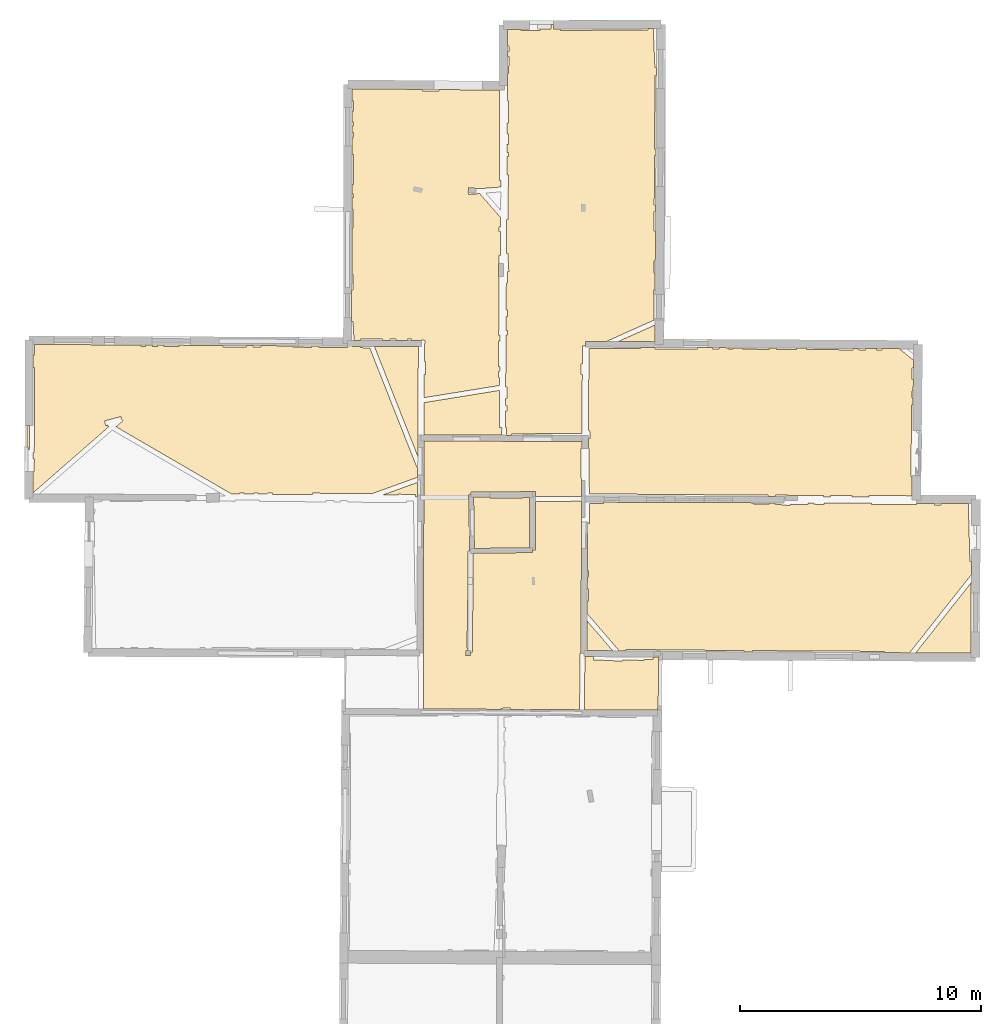
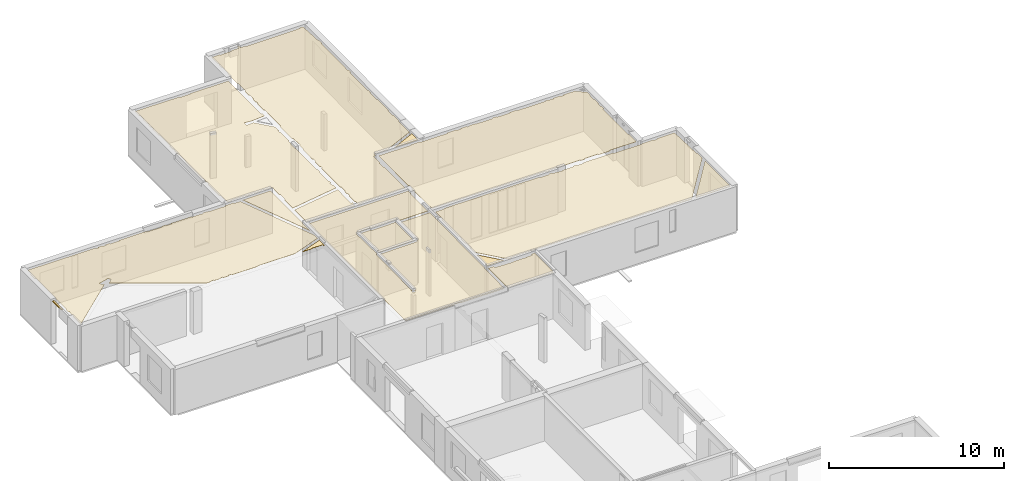
# One storey, part 11 of 14: 15 coverings.
"""IFC2X3 building model written with IfcOpenShell, lengths in metres."""

from ifc_helpers import new_model, entity, si_unit, converted_unit, derived_unit, direction, frame, origin, origin_with_axes, place, context, subcontext, project, spatial, polyline, outline, extrude, material, layer, layer_set, layer_usage, type_object, element, save


model = new_model("IFC2X3")

# Units and contexts
model_context = context("Model", 3, precision=1e-05, world=origin(), true_north=direction((0.0, 1.0)))
body_context = subcontext(model_context, "Body", "Model", "MODEL_VIEW")
ifc_project = project(units=[si_unit("LENGTHUNIT", "METRE"), si_unit("AREAUNIT", "SQUARE_METRE"), si_unit("VOLUMEUNIT", "CUBIC_METRE"), converted_unit("PLANEANGLEUNIT", "DEGREE", entity("IfcRatioMeasure", 0.0174532925199433), si_unit("PLANEANGLEUNIT", "RADIAN"), dimensions=[0, 0, 0, 0, 0, 0, 0]), si_unit("MASSUNIT", "GRAM", prefix="KILO"), derived_unit("MASSDENSITYUNIT", [(si_unit("MASSUNIT", "GRAM", prefix="KILO"), 1), (si_unit("LENGTHUNIT", "METRE"), -3)]), derived_unit("MOMENTOFINERTIAUNIT", [(si_unit("LENGTHUNIT", "METRE"), 4)]), si_unit("TIMEUNIT", "SECOND"), si_unit("FREQUENCYUNIT", "HERTZ"), si_unit("THERMODYNAMICTEMPERATUREUNIT", "DEGREE_CELSIUS"), derived_unit("THERMALTRANSMITTANCEUNIT", [(si_unit("MASSUNIT", "GRAM", prefix="KILO"), 1), (si_unit("THERMODYNAMICTEMPERATUREUNIT", "KELVIN"), -1), (si_unit("TIMEUNIT", "SECOND"), -3)]), derived_unit("VOLUMETRICFLOWRATEUNIT", [(si_unit("LENGTHUNIT", "METRE"), 3), (si_unit("TIMEUNIT", "SECOND"), -1)]), si_unit("ELECTRICCURRENTUNIT", "AMPERE"), si_unit("ELECTRICVOLTAGEUNIT", "VOLT"), si_unit("POWERUNIT", "WATT"), si_unit("FORCEUNIT", "NEWTON", prefix="KILO"), si_unit("ILLUMINANCEUNIT", "LUX"), si_unit("LUMINOUSFLUXUNIT", "LUMEN"), si_unit("LUMINOUSINTENSITYUNIT", "CANDELA"), derived_unit("USERDEFINED", [(si_unit("MASSUNIT", "GRAM", prefix="KILO"), -1), (si_unit("LENGTHUNIT", "METRE"), -2), (si_unit("TIMEUNIT", "SECOND"), 3), (si_unit("LUMINOUSFLUXUNIT", "LUMEN"), 1)]), derived_unit("LINEARVELOCITYUNIT", [(si_unit("LENGTHUNIT", "METRE"), 1), (si_unit("TIMEUNIT", "SECOND"), -1)]), si_unit("PRESSUREUNIT", "PASCAL"), derived_unit("USERDEFINED", [(si_unit("LENGTHUNIT", "METRE"), -2), (si_unit("MASSUNIT", "GRAM", prefix="KILO"), 1), (si_unit("TIMEUNIT", "SECOND"), -2)]), derived_unit("LINEARFORCEUNIT", [(si_unit("MASSUNIT", "GRAM", prefix="KILO"), 1), (si_unit("LENGTHUNIT", "METRE"), 1), (si_unit("TIMEUNIT", "SECOND"), -2), (si_unit("LENGTHUNIT", "METRE"), -1)]), derived_unit("PLANARFORCEUNIT", [(si_unit("MASSUNIT", "GRAM", prefix="KILO"), 1), (si_unit("LENGTHUNIT", "METRE"), 1), (si_unit("TIMEUNIT", "SECOND"), -2), (si_unit("LENGTHUNIT", "METRE"), -2)])], contexts=[model_context])

# Site, building, storey
placement = place(None, origin())
site = spatial("IfcSite", under=ifc_project, at=placement, CompositionType="ELEMENT")
building = spatial("IfcBuilding", under=site, at=placement, CompositionType="ELEMENT")
storey_placement = place(placement, frame((0.0, 0.0, 8.83152770996094)))
storey = spatial("IfcBuildingStorey", under=building, at=storey_placement, Name="Level 4", CompositionType="ELEMENT", Elevation=8.83152770996094)

# Coverings
ifc_material = material(Name="Covering default")
ifc_layer_1 = layer(ifc_material, 0.02)
ifc_layer_set_1 = layer_set([ifc_layer_1], Name="Covering : 20mm")
ifc_layer_usage_1 = layer_usage(ifc_layer_set_1, "AXIS3", "POSITIVE", 0.0)
covering_type_1 = type_object("IfcCoveringType", Name="Covering : 20mm", PredefinedType="CEILING")
covering_1_placement = place(placement, frame((0.0, 0.0, 11.8186979293823)))
element("IfcCovering", 1, at=covering_1_placement, inside=storey, type_object=covering_type_1, material=ifc_layer_usage_1, Name="Covering : 20mm", ObjectType="Covering : 20mm", PredefinedType="CEILING", context=body_context, shape_type="SweptSolid", body=[
    extrude(outline(polyline([(9.79597473144531, 51.0678405761719), (10.1519088745117, 51.0656089782715), (10.1472587585449, 50.9325485229492), (10.9874267578125, 50.9031867980957), (10.9875297546387, 50.8921394348145), (11.3584136962891, 50.8955879211426), (11.3580780029297, 50.9317932128906), (12.2441082000732, 50.9114570617676), (12.2447299957275, 50.9385566711426), (12.6194038391113, 50.9431991577148), (12.6180801391602, 51.0501518249512), (12.8525676727295, 51.0486793518066), (12.8424549102783, 48.9425239562988), (12.8161087036133, 48.9422988891602), (12.8169918060303, 48.840087890625), (9.77705955505371, 48.8573913574219), (9.79597473144531, 51.0678405761719)])), origin_with_axes(), (0.0, 0.0, 1.0), 0.02),
])
ifc_layer_2 = layer(ifc_material, 0.02)
ifc_layer_set_2 = layer_set([ifc_layer_2], Name="Covering : 20mm")
ifc_layer_usage_2 = layer_usage(ifc_layer_set_2, "AXIS3", "POSITIVE", 0.0)
covering_type_2 = type_object("IfcCoveringType", Name="Covering : 20mm", PredefinedType="CEILING")
covering_2_placement = place(placement, frame((0.0, 0.0, 11.8186979293823)))
element("IfcCovering", 2, at=covering_2_placement, inside=storey, type_object=covering_type_2, material=ifc_layer_usage_2, Name="Covering : 20mm", ObjectType="Covering : 20mm", PredefinedType="CEILING", context=body_context, shape_type="SweptSolid", body=[
    extrude(outline(polyline([(3.1042652130127, 60.0340843200684), (9.67360687255859, 60.002815246582), (9.67216873168945, 59.7157859802246), (9.63630294799805, 59.7155380249023), (9.65003204345703, 57.7263717651367), (7.74869728088379, 57.7208099365234), (7.7475471496582, 57.9211921691895), (7.62069702148438, 57.9204635620117), (7.62067413330078, 57.9234580993652), (5.0699462890625, 57.9058380126953), (5.07052040100098, 57.8058395385742), (4.97053146362305, 57.8043899536133), (5.00455474853516, 55.4620208740234), (4.94209480285645, 55.4621849060059), (4.93848609924316, 54.0982208251953), (4.89542388916016, 51.4237213134766), (4.93140983581543, 51.4231414794922), (4.93115615844727, 51.3274917602539), (4.85261535644531, 51.330738067627), (4.84394454956055, 51.1209182739258), (5.04377365112305, 51.1126594543457), (5.05024337768555, 51.2692070007324), (5.13100433349609, 51.2689933776855), (5.14183235168457, 55.3631134033203), (7.61702537536621, 55.392951965332), (7.61582183837891, 55.4929428100586), (7.74082183837891, 55.4926300048828), (7.74592590332031, 57.5207977294922), (9.65684127807617, 57.5263900756836), (9.65327835083008, 56.8442649841309), (9.65611839294434, 56.8442497253418), (9.65708923339844, 56.7038040161133), (9.62950325012207, 51.1940383911133), (9.59704971313477, 51.1943168640137), (9.57706260681152, 48.8585319519043), (6.69943809509277, 48.8749122619629), (6.69731903076172, 48.9332542419434), (6.3033561706543, 48.9189376831055), (6.30487442016602, 48.8771553039551), (6.18254089355469, 48.8778533935547), (6.18254089355469, 48.8778533935547), (3.08750152587891, 48.8954696655273), (3.1042652130127, 60.0340843200684)])), origin_with_axes(), (0.0, 0.0, 1.0), 0.02),
])
ifc_layer_3 = layer(ifc_material, 0.02)
ifc_layer_set_3 = layer_set([ifc_layer_3], Name="Covering : 20mm")
ifc_layer_usage_3 = layer_usage(ifc_layer_set_3, "AXIS3", "POSITIVE", 0.0)
covering_type_3 = type_object("IfcCoveringType", Name="Covering : 20mm", PredefinedType="CEILING")
covering_3_placement = place(placement, frame((0.0, 0.0, 11.8186979293823)))
element("IfcCovering", 3, at=covering_3_placement, inside=storey, type_object=covering_type_3, material=ifc_layer_usage_3, Name="Covering : 20mm", ObjectType="Covering : 20mm", PredefinedType="CEILING", context=body_context, shape_type="SweptSolid", body=[
    extrude(outline(polyline([(23.5451927185059, 51.2249374389648), (25.8534126281738, 54.147632598877), (25.8400573730469, 51.2117691040039), (23.5451927185059, 51.2249374389648)])), origin_with_axes(), (0.0, 0.0, 1.0), 0.02),
])
ifc_layer_4 = layer(ifc_material, 0.02)
ifc_layer_set_4 = layer_set([ifc_layer_4], Name="Covering : 20mm")
ifc_layer_usage_4 = layer_usage(ifc_layer_set_4, "AXIS3", "POSITIVE", 0.0)
covering_type_4 = type_object("IfcCoveringType", Name="Covering : 20mm", PredefinedType="CEILING")
covering_4_placement = place(placement, frame((0.0, 0.0, 11.8186979293823)))
element("IfcCovering", 4, at=covering_4_placement, inside=storey, type_object=covering_type_4, material=ifc_layer_usage_4, Name="Covering : 20mm", ObjectType="Covering : 20mm", PredefinedType="CEILING", context=body_context, shape_type="SweptSolid", body=[
    extrude(outline(polyline([(11.2198619842529, 51.3089218139648), (11.5025272369385, 51.3071479797363), (11.5031280517578, 51.3660087585449), (16.4032402038574, 51.3160209655762), (16.4027290344238, 51.265926361084), (16.7630500793457, 51.263858795166), (16.7633743286133, 51.3179397583008), (22.2440147399902, 51.2849273681641), (22.2436981201172, 51.2324066162109), (23.2914924621582, 51.2263946533203), (25.8548889160156, 54.4721946716309), (25.8573722839355, 55.0177688598633), (25.7986488342285, 55.0160903930664), (25.7297325134277, 57.4270515441895), (24.5905075073242, 57.4253921508789), (24.5912590026855, 57.373779296875), (24.321102142334, 57.3698425292969), (24.3202972412109, 57.4249992370605), (23.5740928649902, 57.4239120483398), (23.5738945007324, 57.380256652832), (21.7008628845215, 57.3886566162109), (21.7011108398438, 57.4442024230957), (19.7317771911621, 57.4515075683594), (19.7304611206055, 57.3928756713867), (19.2905731201172, 57.4027519226074), (19.2917060852051, 57.4531364440918), (19.0605812072754, 57.4539947509766), (19.060359954834, 57.3939971923828), (18.3142623901367, 57.3967590332031), (18.309024810791, 57.3447685241699), (17.6703071594238, 57.4091186523438), (17.6753463745117, 57.4591293334961), (17.4705448150635, 57.459888458252), (17.4701347351074, 57.4036102294922), (16.8100738525391, 57.4084243774414), (16.8104667663574, 57.4623336791992), (10.5690460205078, 57.4854698181152), (10.5689544677734, 57.4285011291504), (9.98208618164062, 57.4294471740723), (9.98776245117188, 56.6070327758789), (9.9066047668457, 56.6064720153809), (9.89682388305664, 54.652889251709), (9.95647430419922, 54.6515502929688), (9.95019149780273, 54.3716201782227), (9.89542198181152, 54.3728485107422), (9.8929615020752, 53.8816528320312), (9.94919204711914, 53.8815155029297), (9.94796752929688, 53.381420135498), (9.89045906066895, 53.3815612792969), (9.8878345489502, 52.8574829101562), (11.2198619842529, 51.3089218139648)])), origin_with_axes(), (0.0, 0.0, 1.0), 0.02),
])
ifc_layer_5 = layer(ifc_material, 0.02)
ifc_layer_set_5 = layer_set([ifc_layer_5], Name="Covering : 20mm")
ifc_layer_usage_5 = layer_usage(ifc_layer_set_5, "AXIS3", "POSITIVE", 0.0)
covering_type_5 = type_object("IfcCoveringType", Name="Covering : 20mm", PredefinedType="CEILING")
covering_5_placement = place(placement, frame((0.0, 0.0, 11.8186979293823)))
element("IfcCovering", 5, at=covering_5_placement, inside=storey, type_object=covering_type_5, material=ifc_layer_usage_5, Name="Covering : 20mm", ObjectType="Covering : 20mm", PredefinedType="CEILING", context=body_context, shape_type="SweptSolid", body=[
    extrude(outline(polyline([(9.88630676269531, 52.552562713623), (10.9546203613281, 51.3105850219727), (9.88012313842773, 51.3173179626465), (9.88630676269531, 52.552562713623)])), origin_with_axes(), (0.0, 0.0, 1.0), 0.02),
])
ifc_layer_6 = layer(ifc_material, 0.02)
ifc_layer_set_6 = layer_set([ifc_layer_6], Name="Covering : 20mm")
ifc_layer_usage_6 = layer_usage(ifc_layer_set_6, "AXIS3", "POSITIVE", 0.0)
covering_type_6 = type_object("IfcCoveringType", Name="Covering : 20mm", PredefinedType="CEILING")
covering_6_placement = place(placement, frame((0.0, 0.0, 11.8186979293823)))
element("IfcCovering", 6, at=covering_6_placement, inside=storey, type_object=covering_type_6, material=ifc_layer_usage_6, Name="Covering : 20mm", ObjectType="Covering : 20mm", PredefinedType="CEILING", context=body_context, shape_type="SweptSolid", body=[
    extrude(outline(polyline([(5.20309448242188, 55.5638656616211), (7.49106979370117, 55.5914497375488), (7.49630737304688, 57.6725044250488), (5.85460090637207, 57.660026550293), (5.85421752929688, 57.710334777832), (5.17197418212891, 57.7064208984375), (5.20309448242188, 55.5638656616211)])), origin_with_axes(), (0.0, 0.0, 1.0), 0.02),
])
ifc_layer_7 = layer(ifc_material, 0.02)
ifc_layer_set_7 = layer_set([ifc_layer_7], Name="Covering : 20mm")
ifc_layer_usage_7 = layer_usage(ifc_layer_set_7, "AXIS3", "POSITIVE", 0.0)
covering_type_7 = type_object("IfcCoveringType", Name="Covering : 20mm", PredefinedType="CEILING")
covering_7_placement = place(placement, frame((0.0, 0.0, 11.8186979293823)))
element("IfcCovering", 7, at=covering_7_placement, inside=storey, type_object=covering_type_7, material=ifc_layer_usage_7, Name="Covering : 20mm", ObjectType="Covering : 20mm", PredefinedType="CEILING", context=body_context, shape_type="SweptSolid", body=[
    extrude(outline(polyline([(9.94423675537109, 60.1278877258301), (10.0078754425049, 60.1299934387207), (9.99689292907715, 60.4621047973633), (9.94590187072754, 60.4604187011719), (9.96303367614746, 63.8825531005859), (12.1138095855713, 63.8654479980469), (12.114221572876, 63.9171676635742), (12.7050228118896, 63.9129409790039), (12.7038841247559, 63.8622055053711), (14.4741134643555, 63.8524780273438), (14.4745082855225, 63.9113616943359), (15.0933952331543, 63.9078140258789), (15.094181060791, 63.8485565185547), (15.3743343353271, 63.8522720336914), (15.3736190795898, 63.9062042236328), (15.7655944824219, 63.9039611816406), (15.764461517334, 63.853515625), (15.9444160461426, 63.8494720458984), (15.9456157684326, 63.9029235839844), (16.3552093505859, 63.9005813598633), (16.3545379638672, 63.8502731323242), (17.4544830322266, 63.835578918457), (17.4552669525146, 63.8942718505859), (17.7651805877686, 63.8924942016602), (17.7646293640137, 63.838623046875), (18.5846481323242, 63.8302154541016), (18.5852394104004, 63.8877944946289), (19.0051498413086, 63.8853912353516), (19.004768371582, 63.8307876586914), (20.9449501037598, 63.8172378540039), (20.9453468322754, 63.874267578125), (21.1462593078613, 63.8731155395508), (21.1451263427734, 63.8227462768555), (21.4550476074219, 63.815788269043), (21.4562950134277, 63.871337890625), (21.9263534545898, 63.8686447143555), (21.9251556396484, 63.8152389526367), (22.1351013183594, 63.8105239868164), (22.1363792419434, 63.8674392700195), (22.8628120422363, 63.8632736206055), (23.4546356201172, 63.3855247497559), (23.451042175293, 63.0608024597168), (23.3986206054688, 63.0619812011719), (23.3880729675293, 62.5921020507812), (23.4458465576172, 62.5908050537109), (23.4405364990234, 62.1108016967773), (23.3872947692871, 62.1119956970215), (23.3805618286133, 61.8120727539062), (23.4372215270996, 61.8107986450195), (23.4340209960938, 61.5216102600098), (23.3740539550781, 61.522144317627), (23.3476104736328, 58.5619888305664), (23.4012908935547, 58.5615081787109), (23.3923454284668, 57.7524223327637), (21.599193572998, 57.7610321044922), (21.5989227294922, 57.7045860290527), (20.8891525268555, 57.707218170166), (20.8891487121582, 57.7669677734375), (19.9989242553711, 57.7669486999512), (19.9989242553711, 57.7105178833008), (19.7083892822266, 57.7115936279297), (19.7087745666504, 57.7634582519531), (17.7086029052734, 57.7783508300781), (17.7081604003906, 57.7190093994141), (17.398042678833, 57.720157623291), (17.3984565734863, 57.7753143310547), (9.97931480407715, 57.8309593200684), (9.96629333496094, 59.7178153991699), (9.94218063354492, 59.7176475524902), (9.94423675537109, 60.1278877258301)])), origin_with_axes(), (0.0, 0.0, 1.0), 0.02),
])
ifc_layer_8 = layer(ifc_material, 0.02)
ifc_layer_set_8 = layer_set([ifc_layer_8], Name="Covering : 20mm")
ifc_layer_usage_8 = layer_usage(ifc_layer_set_8, "AXIS3", "POSITIVE", 0.0)
covering_type_8 = type_object("IfcCoveringType", Name="Covering : 20mm", PredefinedType="CEILING")
covering_8_placement = place(placement, frame((0.0, 0.0, 11.8186979293823)))
element("IfcCovering", 8, at=covering_8_placement, inside=storey, type_object=covering_type_8, material=ifc_layer_usage_8, Name="Covering : 20mm", ObjectType="Covering : 20mm", PredefinedType="CEILING", context=body_context, shape_type="SweptSolid", body=[
    extrude(outline(polyline([(1.39351749420166, 57.7859420776367), (2.84503746032715, 58.3101654052734), (2.84480285644531, 58.2665061950684), (2.8398494720459, 57.7117805480957), (2.76541900634766, 57.7105102539062), (2.76585578918457, 57.776927947998), (2.76462745666504, 57.7769355773926), (2.76492500305176, 57.8104782104492), (2.05959987640381, 57.8167495727539), (2.05928707122803, 57.781566619873), (1.39351749420166, 57.7859420776367)])), origin_with_axes(), (0.0, 0.0, 1.0), 0.02),
])
ifc_layer_9 = layer(ifc_material, 0.02)
ifc_layer_set_9 = layer_set([ifc_layer_9], Name="Covering : 20mm")
ifc_layer_usage_9 = layer_usage(ifc_layer_set_9, "AXIS3", "POSITIVE", 0.0)
covering_type_9 = type_object("IfcCoveringType", Name="Covering : 20mm", PredefinedType="CEILING")
covering_9_placement = place(placement, frame((0.0, 0.0, 11.8186979293823)))
element("IfcCovering", 9, at=covering_9_placement, inside=storey, type_object=covering_type_9, material=ifc_layer_usage_9, Name="Covering : 20mm", ObjectType="Covering : 20mm", PredefinedType="CEILING", context=body_context, shape_type="SweptSolid", body=[
    extrude(outline(polyline([(-13.1369428634644, 63.6120986938477), (-13.0782527923584, 63.6107788085938), (-13.0685796737671, 64.0417251586914), (-8.64799690246582, 64.0179595947266), (-8.64926433563232, 63.9614639282227), (-8.45931339263916, 63.9571990966797), (-8.45797348022461, 64.0169372558594), (-8.16793346405029, 64.015380859375), (-8.16916179656982, 63.960693359375), (-7.95921516418457, 63.9559783935547), (-7.95790672302246, 64.0142517089844), (-7.69871234893799, 64.0128555297852), (-7.69905853271484, 63.9601440429688), (-7.06899070739746, 63.9560012817383), (-7.06863927841187, 64.0094680786133), (-5.24866485595703, 63.9996871948242), (-5.24877643585205, 63.9451446533203), (-4.26857376098633, 63.9431457519531), (-4.26846885681152, 63.9944152832031), (-3.98908424377441, 63.992919921875), (-3.98864459991455, 63.9368591308594), (-3.65850353240967, 63.939453125), (-3.65890979766846, 63.9911422729492), (-2.32788467407227, 63.9839859008789), (-2.32839012145996, 63.9295959472656), (-1.56835746765137, 63.9225387573242), (-1.5678243637085, 63.9799041748047), (-1.27742576599121, 63.9783401489258), (-1.2782039642334, 63.926025390625), (-0.0742225646972656, 63.9081268310547), (-0.0732746124267578, 63.9718704223633), (0.109495162963867, 63.9708862304688), (0.109466552734375, 63.9618911743164), (0.4630126953125, 63.9607772827148), (0.461806297302246, 63.9069671630859), (0.855916023254395, 63.8981246948242), (2.81802749633789, 58.9277954101562), (2.8484058380127, 58.9397888183594), (2.84480285644531, 58.2665061950684), (2.84709930419922, 58.523551940918), (0.958274841308594, 57.8413925170898), (-1.5144100189209, 57.8598022460938), (-1.514817237854, 57.8050384521484), (-3.18581390380859, 57.8160133361816), (-3.18466281890869, 57.8672904968262), (-3.40460681915283, 57.8722267150879), (-3.40583610534668, 57.8174591064453), (-3.7858772277832, 57.819953918457), (-3.78473663330078, 57.8707580566406), (-3.95469379425049, 57.8745727539062), (-3.95589447021484, 57.8210716247559), (-4.36593818664551, 57.8237648010254), (-4.36481475830078, 57.8737754821777), (-4.56476497650146, 57.8782653808594), (-4.56595897674561, 57.8250770568848), (-4.87330150604248, 57.8270950317383), (-4.87336540222168, 57.8173484802246), (-9.6889705657959, 60.6191024780273), (-9.40222644805908, 60.869384765625), (-9.46798610687256, 60.9447250366211), (-9.49370288848877, 61.0413551330566), (-10.1657667160034, 60.862491607666), (-10.114330291748, 60.6692199707031), (-10.023717880249, 60.6933364868164), (-10.0211820602417, 60.6342811584473), (-9.9733715057373, 60.6363334655762), (-13.1367635726929, 57.8751945495605), (-13.1352481842041, 58.7608337402344), (-13.0971260070801, 58.7599792480469), (-13.0854549407959, 59.2798500061035), (-13.138557434082, 59.2810440063477), (-13.1392707824707, 59.5601348876953), (-13.0891666412354, 59.5600051879883), (-13.0799236297607, 63.0906867980957), (-13.1378355026245, 63.0908393859863), (-13.1369428634644, 63.6120986938477)])), origin_with_axes(), (0.0, 0.0, 1.0), 0.02),
])
ifc_layer_10 = layer(ifc_material, 0.02)
ifc_layer_set_10 = layer_set([ifc_layer_10], Name="Covering : 20mm")
ifc_layer_usage_10 = layer_usage(ifc_layer_set_10, "AXIS3", "POSITIVE", 0.0)
covering_type_10 = type_object("IfcCoveringType", Name="Covering : 20mm", PredefinedType="CEILING")
covering_10_placement = place(placement, frame((0.0, 0.0, 11.8186979293823)))
element("IfcCovering", 10, at=covering_10_placement, inside=storey, type_object=covering_type_10, material=ifc_layer_usage_10, Name="Covering : 20mm", ObjectType="Covering : 20mm", PredefinedType="CEILING", context=body_context, shape_type="SweptSolid", body=[
    extrude(outline(polyline([(2.8508129119873, 59.3894195556641), (2.8752326965332, 63.9531555175781), (1.04693412780762, 63.9589309692383), (2.8508129119873, 59.3894195556641)])), origin_with_axes(), (0.0, 0.0, 1.0), 0.02),
])
ifc_layer_11 = layer(ifc_material, 0.02)
ifc_layer_set_11 = layer_set([ifc_layer_11], Name="Covering : 20mm")
ifc_layer_usage_11 = layer_usage(ifc_layer_set_11, "AXIS3", "POSITIVE", 0.0)
covering_type_11 = type_object("IfcCoveringType", Name="Covering : 20mm", PredefinedType="CEILING")
covering_11_placement = place(placement, frame((0.0, 0.0, 11.8186979293823)))
element("IfcCovering", 11, at=covering_11_placement, inside=storey, type_object=covering_type_11, material=ifc_layer_usage_11, Name="Covering : 20mm", ObjectType="Covering : 20mm", PredefinedType="CEILING", context=body_context, shape_type="SweptSolid", body=[
    extrude(outline(polyline([(-13.3819618225098, 60.6808967590332), (-13.2862329483032, 60.6807327270508), (-13.2888736724854, 59.6721229553223), (-13.3395586013794, 59.6719932556152), (-13.3517389297485, 59.7734909057617), (-13.3835172653198, 59.7735786437988), (-13.3819618225098, 60.6808967590332)])), origin_with_axes(), (0.0, 0.0, 1.0), 0.02),
])
ifc_layer_12 = layer(ifc_material, 0.02)
ifc_layer_set_12 = layer_set([ifc_layer_12], Name="Covering : 20mm")
ifc_layer_usage_12 = layer_usage(ifc_layer_set_12, "AXIS3", "POSITIVE", 0.0)
covering_type_12 = type_object("IfcCoveringType", Name="Covering : 20mm", PredefinedType="CEILING")
covering_12_placement = place(placement, frame((0.0, 0.0, 11.8186979293823)))
element("IfcCovering", 12, at=covering_12_placement, inside=storey, type_object=covering_type_12, material=ifc_layer_usage_12, Name="Covering : 20mm", ObjectType="Covering : 20mm", PredefinedType="CEILING", context=body_context, shape_type="SweptSolid", body=[
    extrude(outline(polyline([(3.1127758026123, 61.6245040893555), (6.25296592712402, 62.1341743469238), (6.24407958984375, 60.5986366271973), (6.34835624694824, 60.5980339050293), (6.32959365844727, 60.2687339782715), (3.1056022644043, 60.2840805053711), (3.1127758026123, 61.6245040893555)])), origin_with_axes(), (0.0, 0.0, 1.0), 0.02),
])
ifc_layer_13 = layer(ifc_material, 0.02)
ifc_layer_set_13 = layer_set([ifc_layer_13], Name="Covering : 20mm")
ifc_layer_usage_13 = layer_usage(ifc_layer_set_13, "AXIS3", "POSITIVE", 0.0)
covering_type_13 = type_object("IfcCoveringType", Name="Covering : 20mm", PredefinedType="CEILING")
covering_13_placement = place(placement, frame((0.0, 0.0, 11.8186979293823)))
element("IfcCovering", 13, at=covering_13_placement, inside=storey, type_object=covering_type_13, material=ifc_layer_usage_13, Name="Covering : 20mm", ObjectType="Covering : 20mm", PredefinedType="CEILING", context=body_context, shape_type="SweptSolid", body=[
    extrude(outline(polyline([(6.49801635742188, 61.2782745361328), (6.55437278747559, 61.2795715332031), (6.54931259155273, 61.4997406005859), (6.49929237365723, 61.498592376709), (6.50097846984863, 61.7900543212891), (6.55582237243652, 61.7896690368652), (6.55920028686523, 62.2682418823242), (6.50374794006348, 62.2686347961426), (6.51630210876465, 64.4379425048828), (6.5753059387207, 64.4398956298828), (6.56934928894043, 64.6200790405273), (6.51734733581543, 64.6183624267578), (6.52071952819824, 65.2013168334961), (6.57236862182617, 65.2001571655273), (6.57842826843262, 65.4700927734375), (6.52228355407715, 65.4713516235352), (6.52880668640137, 66.5985565185547), (6.57675361633301, 66.5982666015625), (6.57962989807129, 67.0760879516602), (6.63455581665039, 67.0792388916016), (6.59140396118164, 67.8303985595703), (6.53591728210449, 67.8272094726562), (6.54400634765625, 69.224983215332), (6.6015453338623, 69.2245864868164), (6.60531044006348, 69.7700042724609), (6.60531044006348, 69.7700042724609), (6.61435699462891, 71.080696105957), (6.55474662780762, 71.0811080932617), (6.55926704406738, 71.8621292114258), (6.61186790466309, 71.8609466552734), (6.615234375, 72.0109100341797), (6.56013488769531, 72.0121459960938), (6.56216049194336, 72.362190246582), (6.61309242248535, 72.3610458374023), (6.62251853942871, 72.7809448242188), (6.5645923614502, 72.7822418212891), (6.56724739074707, 73.2410736083984), (6.62284469604492, 73.2410507202148), (6.62327194213867, 74.1512680053711), (6.5725154876709, 74.1512908935547), (6.57624053955078, 74.7952499389648), (6.57723045349121, 74.7952499389648), (6.57842636108398, 75.3018341064453), (6.62908935546875, 75.3014221191406), (6.63480186462402, 76.0014724731445), (6.58008003234863, 76.0019226074219), (6.58059692382812, 76.2200622558594), (6.63973999023438, 76.2214202880859), (6.63467788696289, 76.4415893554688), (6.58111763000488, 76.4403610229492), (6.58276176452637, 77.1364059448242), (7.1481990814209, 77.1390228271484), (7.14914131164551, 77.0802001953125), (7.92961883544922, 77.0926895141602), (7.92877960205078, 77.1451263427734), (8.38950538635254, 77.1469268798828), (8.38875770568848, 77.3384857177734), (8.49855995178223, 77.3381500244141), (8.49945068359375, 77.1452560424805), (8.78957748413086, 77.146598815918), (8.78984832763672, 77.0933837890625), (12.4211807250977, 77.1118927001953), (12.4209175109863, 77.1633911132812), (12.6387367248535, 77.1643981933594), (12.7060890197754, 75.5450973510742), (12.7638454437256, 75.5475006103516), (12.7620258331299, 75.2146377563477), (12.7086791992188, 75.2149658203125), (12.6899909973145, 72.1546020507812), (12.7452964782715, 72.1542663574219), (12.7438220977783, 71.8844985961914), (12.6839294433594, 71.8846740722656), (12.6779117584229, 69.8342895507812), (12.7326126098633, 69.8341293334961), (12.7311935424805, 69.5744934082031), (12.6720771789551, 69.5743637084961), (12.6738929748535, 68.7641143798828), (12.7267646789551, 68.7642364501953), (12.7199306488037, 67.5138549804688), (12.6658325195312, 67.5139846801758), (12.664608001709, 67.0138854980469), (12.7171955108643, 67.0137557983398), (12.7134170532227, 66.3226165771484), (12.6591205596924, 66.3238372802734), (12.6550807952881, 66.1438751220703), (12.672435760498, 66.1434860229492), (12.6664638519287, 65.0509033203125), (10.6938133239746, 64.1673431396484), (9.82974624633789, 64.1735229492188), (9.82974624633789, 64.1735229492188), (9.82974624633789, 64.1735229492188), (9.8283863067627, 63.9836273193359), (9.69354057312012, 63.9842987060547), (9.68976211547852, 63.2296943664551), (9.63894271850586, 63.2308349609375), (9.62906646728516, 62.7909469604492), (9.68755912780762, 62.7896347045898), (9.6752986907959, 60.3407173156738), (6.74299812316895, 60.3250999450684), (6.74330902099609, 60.2667655944824), (6.52986335754395, 60.2677803039551), (6.54836654663086, 60.5925178527832), (6.49982070922852, 60.5952835083008), (6.49801635742188, 61.2782745361328)])), origin_with_axes(), (0.0, 0.0, 1.0), 0.02),
])
ifc_layer_14 = layer(ifc_material, 0.02)
ifc_layer_set_14 = layer_set([ifc_layer_14], Name="Covering : 20mm")
ifc_layer_usage_14 = layer_usage(ifc_layer_set_14, "AXIS3", "POSITIVE", 0.0)
covering_type_14 = type_object("IfcCoveringType", Name="Covering : 20mm", PredefinedType="CEILING")
covering_14_placement = place(placement, frame((0.0, 0.0, 11.8186979293823)))
element("IfcCovering", 14, at=covering_14_placement, inside=storey, type_object=covering_type_14, material=ifc_layer_usage_14, Name="Covering : 20mm", ObjectType="Covering : 20mm", PredefinedType="CEILING", context=body_context, shape_type="SweptSolid", body=[
    extrude(outline(polyline([(0.106295585632324, 66.3037261962891), (0.165533065795898, 66.3042221069336), (0.160125732421875, 66.9545135498047), (0.107438087463379, 66.9540786743164), (0.108982086181641, 67.8332901000977), (0.11082935333252, 68.8851089477539), (0.1634521484375, 68.8849182128906), (0.166203498840332, 69.6535797119141), (0.112178802490234, 69.6537704467773), (0.113055229187012, 70.1526947021484), (0.171960830688477, 70.1550521850586), (0.165554046630859, 70.3152313232422), (0.113337516784668, 70.3131408691406), (0.114007949829102, 70.6950302124023), (0.174081802368164, 70.6951370239258), (0.171918869018555, 71.9355010986328), (0.116186141967773, 71.9354019165039), (0.117401123046875, 72.6268997192383), (0.167410850524902, 72.6257781982422), (0.172348022460938, 72.8457183837891), (0.11778736114502, 72.8469390869141), (0.118261337280273, 73.1170043945312), (0.168410301208496, 73.1158752441406), (0.172225952148438, 73.2858276367188), (0.118559837341309, 73.2870330810547), (0.119348526000977, 73.7359008789062), (0.172327041625977, 73.7359466552734), (0.171979904174805, 74.1660614013672), (0.12010383605957, 74.1660232543945), (0.120985984802246, 74.6682815551758), (3.04252052307129, 74.6414566040039), (3.04203414916992, 74.5817489624023), (3.74208068847656, 74.576042175293), (3.74256134033203, 74.6350326538086), (6.24225234985352, 74.6120834350586), (6.24906158447266, 70.8488311767578), (6.30339813232422, 70.8489303588867), (6.3018627166748, 70.5835037231445), (5.40523529052734, 70.5134353637695), (4.96420288085938, 70.5563278198242), (4.95662117004395, 70.4783782958984), (4.95041084289551, 70.4778900146484), (4.95315742492676, 70.4427490234375), (4.94484329223633, 70.3572692871094), (4.95995140075684, 70.3557968139648), (4.96599197387695, 70.2784957885742), (5.40335655212402, 70.3126754760742), (5.42818450927734, 70.3102569580078), (6.29450035095215, 69.3113708496094), (6.29222106933594, 68.9173736572266), (6.23573875427246, 68.9186401367188), (6.23169898986816, 68.7386932373047), (6.29117965698242, 68.7373580932617), (6.28545570373535, 67.7482528686523), (6.22947311401367, 67.7484970092773), (6.22947311401367, 67.7484970092773), (6.22947311401367, 67.7484970092773), (6.22796440124512, 67.3992156982422), (6.21050071716309, 67.3993835449219), (6.2054386138916, 66.8744049072266), (6.2256965637207, 66.8742065429688), (6.21517372131348, 64.4379806518555), (6.26629638671875, 64.4377593994141), (6.26485061645508, 64.1878433227539), (6.20956230163574, 64.1880416870117), (6.20576858520508, 63.1278610229492), (6.25871467590332, 63.1276702880859), (6.25750732421875, 62.9189987182617), (6.20105361938477, 62.9179153442383), (6.20566368103027, 62.6777496337891), (6.25611686706543, 62.6787185668945), (6.2541389465332, 62.3369827270508), (3.11386108398438, 61.8273010253906), (3.11898994445801, 62.7859916687012), (3.17732620239258, 62.7857437133789), (3.17967224121094, 63.3358306884766), (3.12193298339844, 63.3360786437988), (3.12553596496582, 64.0093307495117), (3.12916946411133, 64.0087814331055), (3.15920639038086, 64.2065124511719), (3.01619529724121, 64.2282333374023), (3.01231956481934, 64.2027206420898), (2.5990104675293, 64.2040328979492), (2.60024642944336, 64.2590637207031), (2.43029022216797, 64.2628784179688), (2.42898178100586, 64.2045669555664), (1.95119571685791, 64.2060775756836), (1.95018577575684, 64.2636566162109), (1.70002460479736, 64.2592697143555), (1.70094394683838, 64.2068634033203), (1.3806791305542, 64.207878112793), (1.38010597229004, 64.2664489746094), (0.479883193969727, 64.2666549682617), (0.47862720489502, 64.2107238769531), (0.202733993530273, 64.2116012573242), (0.156352996826172, 65.0041046142578), (0.104007720947266, 65.0010375976562), (0.106295585632324, 66.3037261962891)])), origin_with_axes(), (0.0, 0.0, 1.0), 0.02),
])
ifc_layer_15 = layer(ifc_material, 0.02)
ifc_layer_set_15 = layer_set([ifc_layer_15], Name="Covering : 20mm")
ifc_layer_usage_15 = layer_usage(ifc_layer_set_15, "AXIS3", "POSITIVE", 0.0)
covering_type_15 = type_object("IfcCoveringType", Name="Covering : 20mm", PredefinedType="CEILING")
covering_15_placement = place(placement, frame((0.0, 0.0, 11.8186979293823)))
element("IfcCovering", 15, at=covering_15_placement, inside=storey, type_object=covering_type_15, material=ifc_layer_usage_15, Name="Covering : 20mm", ObjectType="Covering : 20mm", PredefinedType="CEILING", context=body_context, shape_type="SweptSolid", body=[
    extrude(outline(polyline([(11.1753845214844, 64.1638946533203), (12.7153854370117, 64.8536682128906), (12.7115535736084, 64.1529006958008), (11.1753845214844, 64.1638946533203)])), origin_with_axes(), (0.0, 0.0, 1.0), 0.02),
])

save(model, "model.ifc")
